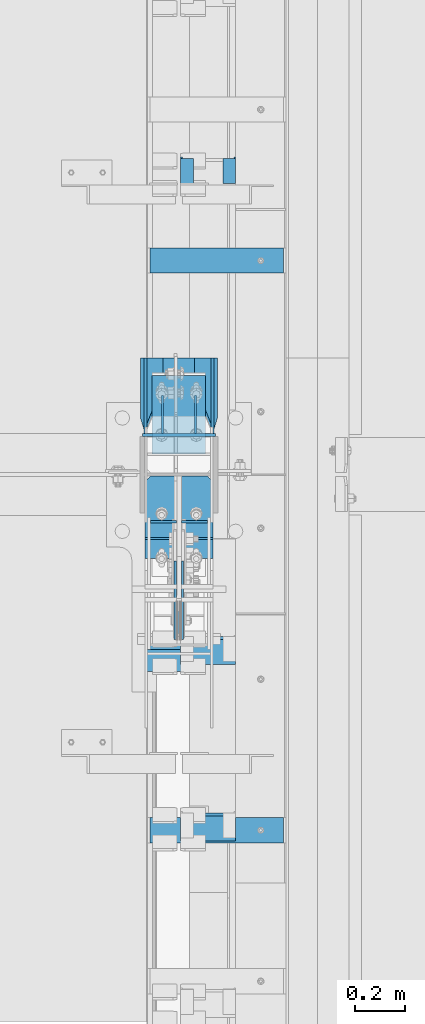
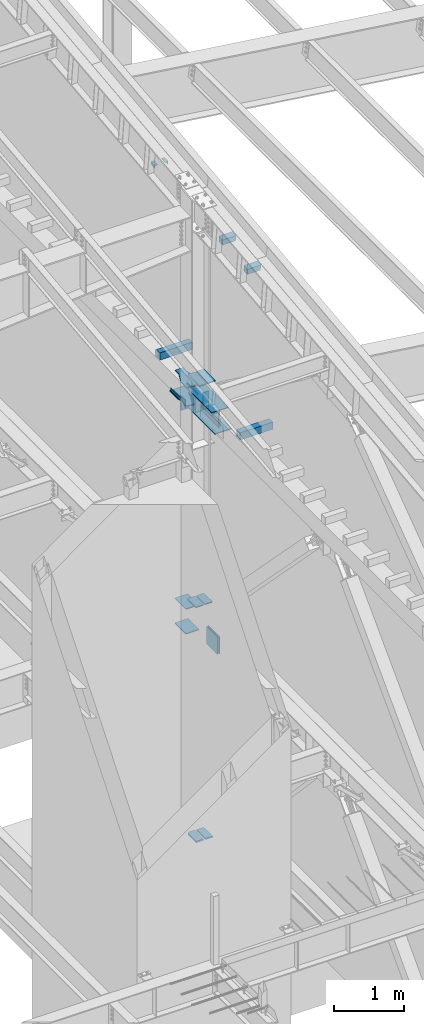
# One storey, part 838 of 1179: 28 beams, 14 elements without a shape of their own.
"""IFC2X3 building model written with IfcOpenShell, lengths in millimetres."""

from ifc_helpers import new_model, si_unit, frame, origin_with_axes, place, context, subcontext, project, spatial, faceted_brep, material, type_object, element, aggregate, save


model = new_model("IFC2X3")

# Units and contexts
model_context = context("Model", 3, precision=1e-05, world=origin_with_axes())
body_context = subcontext(model_context, "Body", "Model", "MODEL_VIEW")
ifc_project = project(units=[si_unit("LENGTHUNIT", "METRE", prefix="MILLI"), si_unit("AREAUNIT", "SQUARE_METRE"), si_unit("VOLUMEUNIT", "CUBIC_METRE"), si_unit("MASSUNIT", "GRAM", prefix="KILO"), si_unit("TIMEUNIT", "SECOND"), si_unit("PLANEANGLEUNIT", "RADIAN"), si_unit("SOLIDANGLEUNIT", "STERADIAN"), si_unit("THERMODYNAMICTEMPERATUREUNIT", "DEGREE_CELSIUS"), si_unit("LUMINOUSINTENSITYUNIT", "LUMEN")], contexts=[model_context])

# Site, building, storey
site_placement = place(None, origin_with_axes())
site = spatial("IfcSite", under=ifc_project, at=site_placement, CompositionType="ELEMENT")
building_placement = place(site_placement, origin_with_axes())
building = spatial("IfcBuilding", under=site, at=building_placement, Name="Undefined", CompositionType="ELEMENT")
storey_placement = place(building_placement, origin_with_axes())
storey = spatial("IfcBuildingStorey", under=building, at=storey_placement, Name="Undefined", CompositionType="ELEMENT", Elevation=0.0)

# Assembly, beam
assembly_1_placement = place(storey_placement, origin_with_axes())
assembly_1 = element("IfcElementAssembly", 1, at=assembly_1_placement, inside=storey, Name="COLUMN", AssemblyPlace="NOTDEFINED", PredefinedType="RIGID_FRAME")
ifc_material_1 = material(Name="STEEL/A36")
beam_type_1 = type_object("IfcBeamType", PredefinedType="NOTDEFINED")
beam_1_placement = place(assembly_1_placement, frame((24160.1625, 19388.1375, 7620.00000000912), z_axis=(0.0, 0.0, 1.0), x_axis=(1.0, 0.0, 0.0)))
beam_1 = element("IfcBeam", 2, at=beam_1_placement, type_object=beam_type_1, material=ifc_material_1, Name="PLATE", context=body_context, shape_type="Brep", body=[
    faceted_brep([(-7.27595761418343e-12, 6.35000000000036, -76.1999999999971), (0.0, 6.35000000000036, 76.2000000000044), (295.274999999994, 6.34999999999854, 76.2000000000007), (295.274999999994, 6.34999999999854, -76.2000000000007), (0.0, -6.35000000000036, 76.2000000000044), (295.274999999994, -6.34999999999854, 76.2000000000007), (7.27595761418343e-12, -6.35000000000036, -76.1999999999971), (295.274999999994, -6.34999999999854, -76.2000000000007)], [[[0, 1, 2, 3]], [[1, 4, 5, 2]], [[4, 6, 7, 5]], [[6, 0, 3, 7]], [[5, 7, 3, 2]], [[6, 4, 1, 0]]]),
])

assembly_2_placement = place(storey_placement, origin_with_axes())
assembly_2 = element("IfcElementAssembly", 3, at=assembly_2_placement, inside=storey, Name="PLATE", AssemblyPlace="NOTDEFINED", PredefinedType="RIGID_FRAME")
ifc_material_2 = material(Name="STEEL/A572-GR.50")
beam_type_2 = type_object("IfcBeamType", PredefinedType="NOTDEFINED")
beam_2_placement = place(assembly_2_placement, frame((24381.619, 18974.0139016605, 4353.48812891869), z_axis=(1.0, 0.0, 0.0), x_axis=(0.0, 1.0, 0.0)))
beam_2 = element("IfcBeam", 4, at=beam_2_placement, type_object=beam_type_2, material=ifc_material_2, Name="PLATE", context=body_context, shape_type="Brep", body=[
    faceted_brep([(225.211098339509, -9.52499999999964, 62.7065000000002), (247.436098339509, -9.52499999999964, 40.4815000000017), (247.436098339509, 9.52499999999964, 40.4815000000017), (225.211098339509, 9.52499999999964, 62.7065000000002), (247.436098339509, 9.52499999999964, -62.7065000000002), (6.18456397205591e-11, 9.52499999999964, -62.7065000000084), (0.0, 9.52499999999964, 62.7065000000002), (0.0, -9.52499999999964, 62.7065000000002), (6.18456397205591e-11, -9.52499999999964, -62.7065000000084), (247.436098339509, -9.52499999999964, -62.7065000000002)], [[[0, 1, 2, 3]], [[4, 5, 6, 3, 2]], [[6, 7, 0, 3]], [[7, 8, 9, 1, 0]], [[8, 5, 4, 9]], [[9, 4, 2, 1]], [[8, 7, 6, 5]]]),
])
aggregate(assembly_2, [beam_2])

assembly_3_placement = place(storey_placement, origin_with_axes())
assembly_3 = element("IfcElementAssembly", 5, at=assembly_3_placement, inside=storey, Name="PLATE", AssemblyPlace="NOTDEFINED", PredefinedType="RIGID_FRAME")
beam_3_placement = place(assembly_3_placement, frame((24233.981, 18974.0139016605, 4353.48812891869), z_axis=(-1.0, 0.0, 0.0), x_axis=(0.0, 1.0, 0.0)))
beam_3 = element("IfcBeam", 6, at=beam_3_placement, type_object=beam_type_2, material=ifc_material_2, Name="PLATE", context=body_context, shape_type="Brep", body=[
    faceted_brep([(225.211098339509, -9.52499999999964, 62.7065000000002), (247.436098339509, -9.52499999999964, 40.4815000000017), (247.436098339509, 9.52499999999964, 40.4815000000017), (225.211098339509, 9.52499999999964, 62.7065000000002), (247.436098339509, 9.52499999999964, -62.7065000000002), (6.18456397205591e-11, 9.52499999999964, -62.7065000000084), (0.0, 9.52499999999964, 62.7065000000002), (0.0, -9.52499999999964, 62.7065000000002), (6.18456397205591e-11, -9.52499999999964, -62.7065000000084), (247.436098339509, -9.52499999999964, -62.7065000000002)], [[[0, 1, 2, 3]], [[4, 5, 6, 3, 2]], [[6, 7, 0, 3]], [[7, 8, 9, 1, 0]], [[8, 5, 4, 9]], [[9, 4, 2, 1]], [[8, 7, 6, 5]]]),
])
aggregate(assembly_3, [beam_3])

# Beam
beam_type_3 = type_object("IfcBeamType", PredefinedType="NOTDEFINED")
beam_4_placement = place(assembly_1_placement, frame((24307.8, 19310.35, 3676.65), z_axis=(1.0, 0.0, 0.0), x_axis=(0.0, 1.0, 0.0)))
beam_4 = element("IfcBeam", 7, at=beam_4_placement, type_object=beam_type_3, material=ifc_material_2, Name="PLATE", context=body_context, shape_type="Brep", body=[
    faceted_brep([(0.0, 6.35000000000036, -107.949999999997), (0.0, 6.35000000000036, 107.949999999997), (317.5, 6.35000000000036, 107.949999999997), (317.5, 6.35000000000036, -107.949999999997), (0.0, -6.35000000000036, 107.949999999997), (317.5, -6.35000000000036, 107.949999999997), (0.0, -6.35000000000036, -107.949999999997), (317.5, -6.35000000000036, -107.949999999997)], [[[0, 1, 2, 3]], [[1, 4, 5, 2]], [[4, 6, 7, 5]], [[6, 0, 3, 7]], [[5, 7, 3, 2]], [[6, 4, 1, 0]]]),
])

beam_5_placement = place(assembly_1_placement, frame((24307.8, 19310.35, 4108.45), z_axis=(1.0, 0.0, 0.0), x_axis=(0.0, 1.0, 0.0)))
beam_5 = element("IfcBeam", 8, at=beam_5_placement, type_object=beam_type_3, material=ifc_material_2, Name="PLATE", context=body_context, shape_type="Brep", body=[
    faceted_brep([(0.0, 6.35000000000036, -107.949999999997), (0.0, 6.35000000000036, 107.949999999997), (317.5, 6.35000000000036, 107.949999999997), (317.5, 6.35000000000036, -107.949999999997), (0.0, -6.35000000000036, 107.949999999997), (317.5, -6.35000000000036, 107.949999999997), (0.0, -6.35000000000036, -107.949999999997), (317.5, -6.35000000000036, -107.949999999997)], [[[0, 1, 2, 3]], [[1, 4, 5, 2]], [[4, 6, 7, 5]], [[6, 0, 3, 7]], [[5, 7, 3, 2]], [[6, 4, 1, 0]]]),
])

# Assembly, beam
assembly_4_placement = place(storey_placement, origin_with_axes())
assembly_4 = element("IfcElementAssembly", 9, at=assembly_4_placement, inside=storey, Name="BEAM", AssemblyPlace="NOTDEFINED", PredefinedType="RIGID_FRAME")
beam_type_4 = type_object("IfcBeamType", Name="L2X2X1/4", PredefinedType="NOTDEFINED")
beam_6_placement = place(assembly_4_placement, frame((24511.0, 20405.3138166334, 11117.474837043), z_axis=(0.0, 0.112284087038014, -0.993676146336441), x_axis=(0.0, 0.993676146336441, 0.112284087038017)))
beam_6 = element("IfcBeam", 10, at=beam_6_placement, type_object=beam_type_4, material=ifc_material_1, Name="ANGLE", ObjectType="L2X2X1/4", context=body_context, shape_type="Brep", body=[
    faceted_brep([(0.0, 25.3999999999996, -25.4000000000015), (0.0, 25.3999999999996, 25.4000000000015), (101.599999999555, 25.4, 25.3999999999451), (101.599999999537, 25.4, -25.4000000000251), (7.27595761418343e-12, 19.05, 25.3999999999851), (101.599999999555, 19.05, 25.3999999999451), (0.0, 19.0499992350015, -19.0499992349996), (101.600003324515, 19.0499992350051, -19.0499992350015), (-1.09139364212751e-11, -25.4, -19.0499999999865), (101.59999999954, -25.4, -19.0500000000302), (0.0, -25.3999999999996, -25.4000000000015), (101.599999999537, -25.4, -25.4000000000251)], [[[0, 1, 2, 3]], [[1, 4, 5, 2]], [[4, 6, 7, 5]], [[6, 8, 9, 7]], [[8, 10, 11, 9]], [[10, 0, 3, 11]], [[5, 7, 9, 11, 3, 2]], [[10, 8, 6, 4, 1, 0]]]),
])
aggregate(assembly_4, [beam_6])

assembly_5_placement = place(storey_placement, origin_with_axes())
assembly_5 = element("IfcElementAssembly", 11, at=assembly_5_placement, inside=storey, Name="BEAM", AssemblyPlace="NOTDEFINED", PredefinedType="RIGID_FRAME")
beam_7_placement = place(assembly_5_placement, frame((24340.34375, 20405.3138166334, 11117.474837043), z_axis=(1.0, 0.0, 0.0), x_axis=(0.0, 0.993676146336441, 0.112284087038017)))
beam_7 = element("IfcBeam", 12, at=beam_7_placement, type_object=beam_type_4, material=ifc_material_1, Name="ANGLE", ObjectType="L2X2X1/4", context=body_context, shape_type="Brep", body=[
    faceted_brep([(0.0, 25.3999999999996, -25.4000000000015), (0.0, 25.3999999999996, 25.4000000000015), (101.599999999555, 25.4, 25.3999999999451), (101.599999999537, 25.4, -25.4000000000251), (7.27595761418343e-12, 19.05, 25.3999999999851), (101.599999999555, 19.05, 25.3999999999451), (0.0, 19.0499992350015, -19.0499992349996), (101.600003324515, 19.0499992350051, -19.0499992350015), (-1.09139364212751e-11, -25.4, -19.0499999999865), (101.59999999954, -25.4, -19.0500000000302), (0.0, -25.3999999999996, -25.4000000000015), (101.599999999537, -25.4, -25.4000000000251)], [[[0, 1, 2, 3]], [[1, 4, 5, 2]], [[4, 6, 7, 5]], [[6, 8, 9, 7]], [[8, 10, 11, 9]], [[10, 0, 3, 11]], [[5, 7, 9, 11, 3, 2]], [[10, 8, 6, 4, 1, 0]]]),
])
aggregate(assembly_5, [beam_7])

# Beam
beam_type_5 = type_object("IfcBeamType", PredefinedType="NOTDEFINED")
beam_8_placement = place(assembly_1_placement, frame((24234.775, 18888.9023695225, 8262.24369604468), z_axis=(-1.0, 0.0, 0.0), x_axis=(0.0, 1.0, 0.0)))
beam_8 = element("IfcBeam", 13, at=beam_8_placement, type_object=beam_type_5, material=ifc_material_2, Name="PLATE", context=body_context, shape_type="Brep", body=[
    faceted_brep([(332.547630477533, 9.52499999999964, 41.2750000000015), (310.322630477534, 9.52499999999964, 63.5), (310.322630477534, -9.52499999999964, 63.5), (332.547630477533, -9.52499999999964, 41.2750000000015), (332.547630477533, 9.52499999999964, -63.5), (0.0, 9.52500000000146, -63.5), (0.0, 9.52500000000146, 63.5), (0.0, -9.52500000000146, 63.5), (0.0, -9.52500000000146, -63.5), (332.547630477533, -9.52499999999964, -63.5)], [[[0, 1, 2, 3]], [[4, 5, 6, 1, 0]], [[6, 7, 2, 1]], [[7, 8, 9, 3, 2]], [[8, 5, 4, 9]], [[9, 4, 0, 3]], [[8, 7, 6, 5]]]),
])

beam_9_placement = place(assembly_1_placement, frame((24380.825, 18888.9023695225, 8262.24369604468), z_axis=(-1.0, 0.0, 0.0), x_axis=(0.0, 1.0, 0.0)))
beam_9 = element("IfcBeam", 14, at=beam_9_placement, type_object=beam_type_5, material=ifc_material_2, Name="PLATE", context=body_context, shape_type="Brep", body=[
    faceted_brep([(310.322630477534, 9.52499999999964, -63.5), (332.547630477533, 9.52499999999964, -41.2750000000015), (332.547630477533, -9.52499999999964, -41.2750000000015), (310.322630477534, -9.52499999999964, -63.5), (0.0, 9.52500000000146, -63.5), (0.0, 9.52500000000146, 63.5), (332.547630477533, 9.52499999999964, 63.5), (0.0, -9.52500000000146, 63.5), (332.547630477533, -9.52499999999964, 63.5), (0.0, -9.52500000000146, -63.5)], [[[0, 1, 2, 3]], [[4, 5, 6, 1, 0]], [[5, 7, 8, 6]], [[8, 7, 9, 3, 2]], [[9, 4, 0, 3]], [[6, 8, 2, 1]], [[9, 7, 5, 4]]]),
])

beam_type_6 = type_object("IfcBeamType", PredefinedType="NOTDEFINED")
beam_10_placement = place(assembly_1_placement, frame((24307.8, 19221.45, 7861.3), z_axis=(0.0, 0.0, 1.0), x_axis=(0.0, -1.0, 0.0)))
beam_10 = element("IfcBeam", 15, at=beam_10_placement, type_object=beam_type_6, material=ifc_material_2, Name="PLATE", context=body_context, shape_type="Brep", body=[
    faceted_brep([(0.0, 9.52500000000146, -152.4), (0.0, 9.52500000000146, 152.4), (676.100196486103, 9.52500000000146, 152.4), (676.100196486103, 9.52500000000146, -152.4), (0.0, -9.52500000000146, 152.4), (676.100196486103, -9.52500000000146, 152.4), (0.0, -9.52500000000146, -152.4), (676.100196486103, -9.52500000000146, -152.4)], [[[0, 1, 2, 3]], [[1, 4, 5, 2]], [[4, 6, 7, 5]], [[6, 0, 3, 7]], [[5, 7, 3, 2]], [[6, 4, 1, 0]]]),
])

beam_type_7 = type_object("IfcBeamType", PredefinedType="NOTDEFINED")
beam_11_placement = place(assembly_1_placement, frame((24317.325, 19037.3, 7861.3), z_axis=(0.0, 0.0, 1.0), x_axis=(1.0, 0.0, 0.0)))
beam_11 = element("IfcBeam", 16, at=beam_11_placement, type_object=beam_type_7, material=ifc_material_2, Name="PLATE", context=body_context, shape_type="Brep", body=[
    faceted_brep([(0.0, 4.76250000000073, -152.4), (0.0, 4.76250000000073, 152.4), (104.775000000001, 4.76250000000073, 152.4), (104.775000000001, 4.76250000000073, -152.4), (0.0, -4.76250000000073, 152.4), (104.775000000001, -4.76250000000073, 152.4), (0.0, -4.76250000000073, -152.4), (104.775000000001, -4.76250000000073, -152.4)], [[[0, 1, 2, 3]], [[1, 4, 5, 2]], [[4, 6, 7, 5]], [[6, 0, 3, 7]], [[5, 7, 3, 2]], [[6, 4, 1, 0]]]),
])

beam_12_placement = place(assembly_1_placement, frame((24193.5, 19037.3, 7861.3), z_axis=(0.0, 0.0, 1.0), x_axis=(1.0, 0.0, 0.0)))
beam_12 = element("IfcBeam", 17, at=beam_12_placement, type_object=beam_type_7, material=ifc_material_2, Name="PLATE", context=body_context, shape_type="Brep", body=[
    faceted_brep([(0.0, 4.76250000000073, -152.4), (0.0, 4.76250000000073, 152.4), (104.775000000001, 4.76250000000073, 152.4), (104.775000000001, 4.76250000000073, -152.4), (0.0, -4.76250000000073, 152.4), (104.775000000001, -4.76250000000073, 152.4), (0.0, -4.76250000000073, -152.4), (104.775000000001, -4.76250000000073, -152.4)], [[[0, 1, 2, 3]], [[1, 4, 5, 2]], [[4, 6, 7, 5]], [[6, 0, 3, 7]], [[5, 7, 3, 2]], [[6, 4, 1, 0]]]),
])

beam_type_8 = type_object("IfcBeamType", PredefinedType="NOTDEFINED")
beam_13_placement = place(assembly_1_placement, frame((24307.8, 18434.2248035139, 7702.55), z_axis=(-1.0, 0.0, 0.0), x_axis=(0.0, 1.0, 0.0)))
beam_13 = element("IfcBeam", 18, at=beam_13_placement, type_object=beam_type_8, material=ifc_material_2, Name="PLATE", context=body_context, shape_type="Brep", body=[
    faceted_brep([(765.000197461464, 6.35000000000036, -136.525000000001), (787.225197461465, 6.35000000000036, -114.299999999999), (787.225197461465, -6.35000000000036, -114.299999999999), (765.000197461464, -6.35000000000036, -136.525000000001), (787.225197461465, 6.35000000000036, 114.299999999999), (765.000197461464, 6.35000000000036, 136.525000000001), (765.000197461464, -6.35000000000036, 136.525000000001), (787.225197461465, -6.35000000000036, 114.299999999999), (0.0, 6.35000000000036, -136.525000000001), (0.0, 6.35000000000036, 136.525000000001), (0.0, -6.35000000000036, 136.525000000001), (0.0, -6.35000000000036, -136.525000000001)], [[[0, 1, 2, 3]], [[4, 5, 6, 7]], [[8, 9, 5, 4, 1, 0]], [[9, 10, 6, 5]], [[7, 6, 10, 11, 3, 2]], [[11, 8, 0, 3]], [[4, 7, 2, 1]], [[11, 10, 9, 8]]]),
])

beam_14_placement = place(assembly_1_placement, frame((24307.8, 18523.1248035139, 8020.05), z_axis=(-1.0, 0.0, 0.0), x_axis=(0.0, 1.0, 0.0)))
beam_14 = element("IfcBeam", 19, at=beam_14_placement, type_object=beam_type_8, material=ifc_material_2, Name="PLATE", context=body_context, shape_type="Brep", body=[
    faceted_brep([(676.100197461472, 6.35000000000036, -136.525000000001), (698.325197461472, 6.35000000000036, -114.299999999999), (698.325197461472, -6.35000000000036, -114.299999999999), (676.100197461472, -6.35000000000036, -136.525000000001), (698.325197461472, 6.35000000000036, 114.299999999999), (676.100197461472, 6.35000000000036, 136.525000000001), (676.100197461472, -6.35000000000036, 136.525000000001), (698.325197461472, -6.35000000000036, 114.299999999999), (0.0, 6.35000000000036, -136.525000000001), (0.0, 6.35000000000036, 136.525000000001), (0.0, -6.35000000000036, 136.525000000001), (0.0, -6.35000000000036, -136.525000000001)], [[[0, 1, 2, 3]], [[4, 5, 6, 7]], [[8, 9, 5, 4, 1, 0]], [[9, 10, 6, 5]], [[7, 6, 10, 11, 3, 2]], [[11, 8, 0, 3]], [[4, 7, 2, 1]], [[11, 10, 9, 8]]]),
])

# Assembly, beam
assembly_6_placement = place(storey_placement, origin_with_axes())
assembly_6 = element("IfcElementAssembly", 20, at=assembly_6_placement, inside=storey, Name="PLATE", AssemblyPlace="NOTDEFINED", PredefinedType="RIGID_FRAME")
beam_type_9 = type_object("IfcBeamType", PredefinedType="NOTDEFINED")
beam_15_placement = place(assembly_6_placement, frame((24232.3935, 18966.3380811392, 267.318748335633), z_axis=(-1.0, 0.0, 0.0), x_axis=(0.0, 1.0, 0.0)))
beam_15 = element("IfcBeam", 21, at=beam_15_placement, type_object=beam_type_9, material=ifc_material_2, Name="PLATE", context=body_context, shape_type="Brep", body=[
    faceted_brep([(255.111918860846, 12.7, 38.8940000000002), (232.886918860846, 12.7, 61.1189999999988), (232.886918860846, -12.7, 61.1189999999988), (255.111918860846, -12.7, 38.8940000000002), (255.111918860846, 12.7, -61.1189999999988), (0.0, 12.7, -61.1189999999988), (0.0, 12.7, 61.1189999999988), (0.0, -12.7, 61.1189999999988), (0.0, -12.7, -61.1189999999988), (255.111918860846, -12.7, -61.1189999999988)], [[[0, 1, 2, 3]], [[4, 5, 6, 1, 0]], [[6, 7, 2, 1]], [[7, 8, 9, 3, 2]], [[8, 5, 4, 9]], [[9, 4, 0, 3]], [[8, 7, 6, 5]]]),
])
aggregate(assembly_6, [beam_15])

assembly_7_placement = place(storey_placement, origin_with_axes())
assembly_7 = element("IfcElementAssembly", 22, at=assembly_7_placement, inside=storey, Name="PLATE", AssemblyPlace="NOTDEFINED", PredefinedType="RIGID_FRAME")
beam_16_placement = place(assembly_7_placement, frame((24383.2065, 18966.3380811392, 267.318748335633), z_axis=(1.0, 0.0, 0.0), x_axis=(0.0, 1.0, 0.0)))
beam_16 = element("IfcBeam", 23, at=beam_16_placement, type_object=beam_type_9, material=ifc_material_2, Name="PLATE", context=body_context, shape_type="Brep", body=[
    faceted_brep([(255.111918860846, 12.7, 38.8940000000002), (232.886918860846, 12.7, 61.1189999999988), (232.886918860846, -12.7, 61.1189999999988), (255.111918860846, -12.7, 38.8940000000002), (255.111918860846, 12.7, -61.1189999999988), (0.0, 12.7, -61.1189999999988), (0.0, 12.7, 61.1189999999988), (0.0, -12.7, 61.1189999999988), (0.0, -12.7, -61.1189999999988), (255.111918860846, -12.7, -61.1189999999988)], [[[0, 1, 2, 3]], [[4, 5, 6, 1, 0]], [[6, 7, 2, 1]], [[7, 8, 9, 3, 2]], [[8, 5, 4, 9]], [[9, 4, 0, 3]], [[8, 7, 6, 5]]]),
])
aggregate(assembly_7, [beam_16])

assembly_8_placement = place(storey_placement, origin_with_axes())
assembly_8 = element("IfcElementAssembly", 24, at=assembly_8_placement, inside=storey, Name="PLATE", AssemblyPlace="NOTDEFINED", PredefinedType="RIGID_FRAME")
beam_type_10 = type_object("IfcBeamType", PredefinedType="NOTDEFINED")
beam_17_placement = place(assembly_8_placement, frame((24293.5125, 18562.3015666254, 3892.55), z_axis=(0.0, 0.0, -1.0), x_axis=(0.0, 1.0, 0.0)))
beam_17 = element("IfcBeam", 25, at=beam_17_placement, type_object=beam_type_10, material=ifc_material_2, Name="PLATE", context=body_context, shape_type="Brep", body=[
    faceted_brep([(0.0, 4.76250000000073, -152.4), (0.0, 4.76250000000073, 152.4), (317.5, 4.76250000000073, 152.4), (317.5, 4.76250000000073, -152.4), (0.0, -4.76250000000073, 152.4), (317.5, -4.76250000000073, 152.4), (0.0, -4.76250000000073, -152.4), (317.5, -4.76250000000073, -152.4)], [[[0, 1, 2, 3]], [[1, 4, 5, 2]], [[4, 6, 7, 5]], [[6, 0, 3, 7]], [[5, 7, 3, 2]], [[6, 4, 1, 0]]]),
])
aggregate(assembly_8, [beam_17])

assembly_9_placement = place(storey_placement, origin_with_axes())
assembly_9 = element("IfcElementAssembly", 26, at=assembly_9_placement, inside=storey, Name="PLATE", AssemblyPlace="NOTDEFINED", PredefinedType="RIGID_FRAME")
beam_18_placement = place(assembly_9_placement, frame((24322.0875, 18879.8015666254, 3892.55), z_axis=(0.0, 0.0, -1.0), x_axis=(0.0, -1.0, 0.0)))
beam_18 = element("IfcBeam", 27, at=beam_18_placement, type_object=beam_type_10, material=ifc_material_2, Name="PLATE", context=body_context, shape_type="Brep", body=[
    faceted_brep([(0.0, 4.76250000000073, -152.4), (0.0, 4.76250000000073, 152.4), (317.5, 4.76250000000073, 152.4), (317.5, 4.76250000000073, -152.4), (0.0, -4.76250000000073, 152.4), (317.5, -4.76250000000073, 152.4), (0.0, -4.76250000000073, -152.4), (317.5, -4.76250000000073, -152.4)], [[[0, 1, 2, 3]], [[1, 4, 5, 2]], [[4, 6, 7, 5]], [[6, 0, 3, 7]], [[5, 7, 3, 2]], [[6, 4, 1, 0]]]),
])
aggregate(assembly_9, [beam_18])

# Beam
beam_type_11 = type_object("IfcBeamType", PredefinedType="NOTDEFINED")
beam_19_placement = place(assembly_1_placement, frame((24172.8625, 19699.2875, 7727.95000000912), z_axis=(0.0, 0.0, 1.0), x_axis=(0.0, -1.0, 0.0)))
beam_19 = element("IfcBeam", 28, at=beam_19_placement, type_object=beam_type_11, material=ifc_material_1, Name="PLATE", context=body_context, shape_type="Brep", body=[
    faceted_brep([(0.0, 6.34999999999854, -19.0499999999993), (0.0, 6.35000000000036, 19.0499999999993), (317.5, 6.34999999999854, 19.0499999999993), (317.5, 6.34999999999854, -19.0499999999993), (0.0, -6.35000000000036, 19.0499999999993), (317.5, -6.34999999999854, 19.0499999999993), (0.0, -6.34999999999854, -19.0499999999993), (317.5, -6.34999999999854, -19.0499999999993)], [[[0, 1, 2, 3]], [[1, 4, 5, 2]], [[4, 6, 7, 5]], [[6, 0, 3, 7]], [[5, 7, 3, 2]], [[6, 4, 1, 0]]]),
])

beam_20_placement = place(assembly_1_placement, frame((24442.7375, 19699.2875, 7727.95000000912), z_axis=(0.0, 0.0, 1.0), x_axis=(0.0, -1.0, 0.0)))
beam_20 = element("IfcBeam", 29, at=beam_20_placement, type_object=beam_type_11, material=ifc_material_1, Name="PLATE", context=body_context, shape_type="Brep", body=[
    faceted_brep([(0.0, 6.34999999999854, -19.0499999999993), (0.0, 6.35000000000036, 19.0499999999993), (317.5, 6.34999999999854, 19.0499999999993), (317.5, 6.34999999999854, -19.0499999999993), (0.0, -6.35000000000036, 19.0499999999993), (317.5, -6.34999999999854, 19.0499999999993), (0.0, -6.34999999999854, -19.0499999999993), (317.5, -6.34999999999854, -19.0499999999993)], [[[0, 1, 2, 3]], [[1, 4, 5, 2]], [[4, 6, 7, 5]], [[6, 0, 3, 7]], [[5, 7, 3, 2]], [[6, 4, 1, 0]]]),
])

beam_type_12 = type_object("IfcBeamType", PredefinedType="NOTDEFINED")
beam_21_placement = place(assembly_1_placement, frame((24241.125, 19546.8875, 7620.00000000912), z_axis=(0.0, 0.0, 1.0), x_axis=(0.0, -1.0, 0.0)))
beam_21 = element("IfcBeam", 30, at=beam_21_placement, type_object=beam_type_12, material=ifc_material_1, Name="PLATE", context=body_context, shape_type="Brep", body=[
    faceted_brep([(152.4, -4.76249999999709, 76.2), (152.4, -4.76249999999709, -76.2), (152.4, 4.76249999999709, -76.2), (152.4, 4.76249999999709, 76.2), (0.0, 4.76249999999982, 76.1999999999971), (0.0, -4.76249999999982, 76.1999999999971)], [[[0, 1, 2, 3]], [[3, 2, 4]], [[4, 5, 0, 3]], [[0, 5, 1]], [[4, 2, 1, 5]]]),
])

beam_22_placement = place(assembly_1_placement, frame((24374.475, 19546.8875, 7620.00000000912), z_axis=(0.0, 0.0, 1.0), x_axis=(0.0, -1.0, 0.0)))
beam_22 = element("IfcBeam", 31, at=beam_22_placement, type_object=beam_type_12, material=ifc_material_1, Name="PLATE", context=body_context, shape_type="Brep", body=[
    faceted_brep([(152.4, -4.76249999999709, 76.2), (152.4, -4.76249999999709, -76.2), (152.4, 4.76249999999709, -76.2), (152.4, 4.76249999999709, 76.2), (0.0, 4.76249999999982, 76.1999999999971), (0.0, -4.76249999999982, 76.1999999999971)], [[[0, 1, 2, 3]], [[3, 2, 4]], [[4, 5, 0, 3]], [[0, 5, 1]], [[4, 2, 1, 5]]]),
])

# Assembly, beam
assembly_10_placement = place(storey_placement, origin_with_axes())
assembly_10 = element("IfcElementAssembly", 32, at=assembly_10_placement, inside=storey, Name="PLATE", AssemblyPlace="NOTDEFINED", PredefinedType="RIGID_FRAME")
beam_type_13 = type_object("IfcBeamType", PredefinedType="NOTDEFINED")
beam_23_placement = place(assembly_10_placement, frame((24307.8, 19699.2875, 8023.22500000912), z_axis=(1.0, 0.0, 0.0), x_axis=(0.0, -1.0, 0.0)))
beam_23 = element("IfcBeam", 33, at=beam_23_placement, type_object=beam_type_13, material=ifc_material_1, Name="PLATE", context=body_context, shape_type="Brep", body=[
    faceted_brep([(465.137499999997, -7.9375, -114.300000762945), (442.912499999999, -7.9375, -136.525000762944), (442.912500000006, 7.9375, -136.525000762944), (465.137500000004, 7.9375, -114.300000762945), (465.137500000004, 7.9375, 114.300000762938), (442.912500000006, 7.9375, 136.525000762937), (442.912499999999, -7.9375, 136.525000762937), (465.137499999997, -7.9375, 114.300000762938), (96.7084051981856, -7.9375, 63.4999984741225), (96.7084051981856, 7.9375, 63.4999984741225), (0.0, 7.9375, 63.5), (0.0, -7.9375, 63.5), (99.1209783650102, -7.9375, 63.6148350254298), (99.1209783650102, 7.9375, 63.6148350254298), (101.511736446291, -7.9375, 63.958306298744), (101.511736446291, 7.9375, 63.958306298744), (103.859061613901, -7.9375, 64.5273065415386), (103.859061613901, 7.9375, 64.5273065415386), (106.141728770905, -7.9375, 65.3166907123523), (106.141728770905, 7.9375, 65.3166907123523), (284.162490278406, -7.9375, 136.524999999998), (284.162490278406, 7.9375, 136.525000000001), (0.0, -7.9375, -63.5), (0.0, 7.9375, -63.5), (96.7084055018695, 7.9375, -63.5), (96.7084055018695, -7.9375, -63.5), (99.1209785229439, 7.9375, -63.6148365373992), (99.1209785229439, -7.9375, -63.6148365373992), (101.511736462435, 7.9375, -63.9583077692478), (101.511736462435, -7.9375, -63.9583077692478), (103.859061496114, 7.9375, -64.5273079437611), (103.859061496114, -7.9375, -64.5273079437611), (106.141728530831, 7.9375, -65.3166920207259), (106.141728530831, -7.9375, -65.3166920207259), (284.162502485447, -7.9375, -136.525001525879), (284.162502485447, 7.9375, -136.525000000001)], [[[0, 1, 2, 3]], [[4, 5, 6, 7]], [[8, 9, 10, 11]], [[12, 13, 9, 8]], [[14, 15, 13, 12]], [[16, 17, 15, 14]], [[18, 19, 17, 16]], [[20, 21, 19, 18]], [[22, 23, 24, 25]], [[25, 24, 26, 27]], [[27, 26, 28, 29]], [[29, 28, 30, 31]], [[31, 30, 32, 33]], [[34, 33, 32, 35]], [[34, 35, 2, 1]], [[4, 7, 0, 3]], [[7, 6, 20, 18, 16, 14, 12, 8, 11, 22, 25, 27, 29, 31, 33, 34, 1, 0]], [[22, 11, 10, 23]], [[35, 32, 30, 28, 26, 24, 23, 10, 9, 13, 15, 17, 19, 21, 5, 4, 3, 2]], [[21, 20, 6, 5]]]),
])
aggregate(assembly_10, [beam_23])

assembly_11_placement = place(storey_placement, origin_with_axes())
assembly_11 = element("IfcElementAssembly", 34, at=assembly_11_placement, inside=storey, Name="BEAM", AssemblyPlace="NOTDEFINED", PredefinedType="RIGID_FRAME")
ifc_material_3 = material()
beam_type_14 = type_object("IfcBeamType", Name="HSS4X4X5/16", PredefinedType="NOTDEFINED")
beam_24_placement = place(assembly_11_placement, frame((24307.8, 17805.9346927869, 10900.081017617), z_axis=(0.0, -0.112284087038017, 0.993676146336441), x_axis=(1.0, 0.0, 0.0)))
beam_24 = element("IfcBeam", 35, at=beam_24_placement, type_object=beam_type_14, material=ifc_material_3, Name="BEAM", ObjectType="HSS4X4X5/16", context=body_context, shape_type="Brep", body=[
    faceted_brep([(7.14374999999757, 42.8624999999884, -42.8624999999574), (7.14374999999757, -42.8624999999593, -42.862499999992), (228.600000000002, -42.8624999999593, -42.862499999992), (228.600000000002, 42.8624999999884, -42.8624999999574), (7.14374999999757, -42.8624999999956, 42.8624999999611), (228.600000000002, -42.8624999999956, 42.8624999999611), (7.14374999999757, 42.862499999952, 42.8624999999938), (228.600000000002, 42.862499999952, 42.8624999999938), (7.14374999999757, 50.7999999999884, -50.7999999999502), (7.14374999999757, 50.7999999999447, 50.7999999999938), (228.600000000002, 50.7999999999447, 50.7999999999938), (228.600000000002, 50.7999999999884, -50.7999999999502), (7.14374999999757, -50.7999999999956, 50.799999999952), (228.600000000002, -50.7999999999956, 50.799999999952), (7.14374999999757, -50.7999999999556, -50.7999999999902), (228.600000000002, -50.7999999999556, -50.7999999999902)], [[[0, 1, 2, 3]], [[1, 4, 5, 2]], [[4, 6, 7, 5]], [[6, 0, 3, 7]], [[8, 9, 10, 11]], [[9, 12, 13, 10]], [[12, 14, 15, 13]], [[14, 8, 11, 15]], [[13, 15, 11, 10], [5, 7, 3, 2]], [[14, 12, 9, 8], [6, 4, 1, 0]]]),
])
aggregate(assembly_11, [beam_24])

assembly_12_placement = place(storey_placement, origin_with_axes())
assembly_12 = element("IfcElementAssembly", 36, at=assembly_12_placement, inside=storey, Name="BEAM", AssemblyPlace="NOTDEFINED", PredefinedType="RIGID_FRAME")
beam_25_placement = place(assembly_12_placement, frame((24307.8, 18517.565655167, 10980.5496956301), z_axis=(0.0, -0.112284087038017, 0.993676146336441), x_axis=(1.0, 0.0, 0.0)))
beam_25 = element("IfcBeam", 37, at=beam_25_placement, type_object=beam_type_14, material=ifc_material_3, Name="BEAM", ObjectType="HSS4X4X5/16", context=body_context, shape_type="Brep", body=[
    faceted_brep([(7.14374999999757, 42.8624999999884, -42.8624999999574), (7.14374999999757, -42.8624999999593, -42.862499999992), (228.600000000002, -42.8624999999593, -42.862499999992), (228.600000000002, 42.8624999999884, -42.8624999999574), (7.14374999999757, -42.8624999999956, 42.8624999999611), (228.600000000002, -42.8624999999956, 42.8624999999611), (7.14374999999757, 42.862499999952, 42.8624999999938), (228.600000000002, 42.862499999952, 42.8624999999938), (7.14374999999757, 50.7999999999884, -50.7999999999502), (7.14374999999757, 50.7999999999447, 50.7999999999938), (228.600000000002, 50.7999999999447, 50.7999999999938), (228.600000000002, 50.7999999999884, -50.7999999999502), (7.14374999999757, -50.7999999999956, 50.799999999952), (228.600000000002, -50.7999999999956, 50.799999999952), (7.14374999999757, -50.7999999999556, -50.7999999999902), (228.600000000002, -50.7999999999556, -50.7999999999902)], [[[0, 1, 2, 3]], [[1, 4, 5, 2]], [[4, 6, 7, 5]], [[6, 0, 3, 7]], [[8, 9, 10, 11]], [[9, 12, 13, 10]], [[12, 14, 15, 13]], [[14, 8, 11, 15]], [[13, 15, 11, 10], [5, 7, 3, 2]], [[14, 12, 9, 8], [6, 4, 1, 0]]]),
])
aggregate(assembly_12, [beam_25])

assembly_13_placement = place(storey_placement, origin_with_axes())
assembly_13 = element("IfcElementAssembly", 38, at=assembly_13_placement, inside=storey, Name="BEAM", AssemblyPlace="NOTDEFINED", PredefinedType="RIGID_FRAME")
beam_type_15 = type_object("IfcBeamType", Name="HSS5X4X3/8", PredefinedType="NOTDEFINED")
beam_26_placement = place(assembly_13_placement, frame((24180.8, 20091.4, 8077.19999998781), z_axis=(0.0, 0.0, 1.0), x_axis=(1.0, 0.0, 0.0)))
beam_26 = element("IfcBeam", 39, at=beam_26_placement, type_object=beam_type_15, material=ifc_material_3, Name="BEAM", ObjectType="HSS5X4X3/8", context=body_context, shape_type="Brep", body=[
    faceted_brep([(9.52500000000146, 41.2750000000015, -53.9750000000004), (9.52500000000146, -41.2750000000015, -53.9750000000004), (549.274999999994, -41.2750000000015, -53.9750000000004), (549.274999999994, 41.2750000000015, -53.9750000000004), (9.52500000000146, -41.2750000000015, 53.9750000000004), (549.274999999994, -41.2750000000015, 53.9750000000004), (9.52500000000146, 41.2750000000015, 53.9750000000004), (549.274999999994, 41.2750000000015, 53.9750000000004), (9.52500000000146, 50.7999999999993, -63.5), (9.52500000000146, 50.7999999999993, 63.5), (549.274999999994, 50.7999999999993, 63.5), (549.274999999994, 50.7999999999993, -63.5), (9.52500000000146, -50.7999999999993, 63.5), (549.274999999994, -50.7999999999993, 63.5), (9.52500000000146, -50.7999999999993, -63.5), (549.274999999994, -50.7999999999993, -63.5)], [[[0, 1, 2, 3]], [[1, 4, 5, 2]], [[4, 6, 7, 5]], [[6, 0, 3, 7]], [[8, 9, 10, 11]], [[9, 12, 13, 10]], [[12, 14, 15, 13]], [[14, 8, 11, 15]], [[13, 15, 11, 10], [5, 7, 3, 2]], [[14, 12, 9, 8], [6, 4, 1, 0]]]),
])
aggregate(assembly_13, [beam_26])

assembly_14_placement = place(storey_placement, origin_with_axes())
assembly_14 = element("IfcElementAssembly", 40, at=assembly_14_placement, inside=storey, Name="BEAM", AssemblyPlace="NOTDEFINED", PredefinedType="RIGID_FRAME")
beam_27_placement = place(assembly_14_placement, frame((24180.8, 17792.7, 8077.19999998781), z_axis=(0.0, 0.0, 1.0), x_axis=(1.0, 0.0, 0.0)))
beam_27 = element("IfcBeam", 41, at=beam_27_placement, type_object=beam_type_15, material=ifc_material_3, Name="BEAM", ObjectType="HSS5X4X3/8", context=body_context, shape_type="Brep", body=[
    faceted_brep([(9.52500000000146, 41.2750000000015, -53.9750000000004), (9.52500000000146, -41.2750000000015, -53.9750000000004), (549.274999999994, -41.2750000000015, -53.9750000000004), (549.274999999994, 41.2750000000015, -53.9750000000004), (9.52500000000146, -41.2750000000015, 53.9750000000004), (549.274999999994, -41.2750000000015, 53.9750000000004), (9.52500000000146, 41.2750000000015, 53.9750000000004), (549.274999999994, 41.2750000000015, 53.9750000000004), (9.52500000000146, 50.7999999999993, -63.5), (9.52500000000146, 50.7999999999993, 63.5), (549.274999999994, 50.7999999999993, 63.5), (549.274999999994, 50.7999999999993, -63.5), (9.52500000000146, -50.7999999999993, 63.5), (549.274999999994, -50.7999999999993, 63.5), (9.52500000000146, -50.7999999999993, -63.5), (549.274999999994, -50.7999999999993, -63.5)], [[[0, 1, 2, 3]], [[1, 4, 5, 2]], [[4, 6, 7, 5]], [[6, 0, 3, 7]], [[8, 9, 10, 11]], [[9, 12, 13, 10]], [[12, 14, 15, 13]], [[14, 8, 11, 15]], [[13, 15, 11, 10], [5, 7, 3, 2]], [[14, 12, 9, 8], [6, 4, 1, 0]]]),
])
aggregate(assembly_14, [beam_27])

# Beam
beam_type_16 = type_object("IfcBeamType", PredefinedType="NOTDEFINED")
beam_28_placement = place(assembly_1_placement, frame((24307.8, 19699.2875, 7702.55000000912), z_axis=(1.0, 0.0, 0.0), x_axis=(0.0, -1.0, 0.0)))
beam_28 = element("IfcBeam", 42, at=beam_28_placement, type_object=beam_type_16, material=ifc_material_1, Name="PLATE", context=body_context, shape_type="Brep", body=[
    faceted_brep([(465.137500000001, -6.35000000000036, -114.300000762942), (442.9125, -6.35000000000036, -136.52500076294), (442.9125, 6.35000000000036, -136.52500076294), (465.137500000001, 6.35000000000036, -114.300000762942), (465.137500000001, 6.35000000000036, 114.300000762942), (442.9125, 6.35000000000036, 136.52500076294), (442.9125, -6.35000000000036, 136.52500076294), (465.137500000001, -6.35000000000036, 114.300000762942), (241.300006103516, -6.35000000000036, -155.575000000001), (241.300006103516, 6.35000000000036, -155.575000000001), (304.799990844727, 6.35000000000036, -136.52500076294), (304.799990844727, -6.35000000000036, -136.52500076294), (0.0, -6.35000000000036, -155.575000000001), (0.0, -6.35000000000036, 155.575000000001), (0.0, 6.35000000000036, 155.575000000001), (0.0, 6.35000000000036, -155.575000000001), (241.300006103516, -6.35000000000036, 155.575000000001), (241.300006103516, 6.35000000000036, 155.575000000001), (304.799990844727, -6.35000000000036, 136.52500076294), (304.799990844727, 6.35000000000036, 136.52500076294)], [[[0, 1, 2, 3]], [[4, 5, 6, 7]], [[8, 9, 10, 11]], [[11, 10, 2, 1]], [[12, 13, 14, 15]], [[14, 13, 16, 17]], [[18, 19, 17, 16]], [[19, 18, 6, 5]], [[4, 7, 0, 3]], [[10, 9, 15, 14, 17, 19, 5, 4, 3, 2]], [[12, 15, 9, 8]], [[7, 6, 18, 16, 13, 12, 8, 11, 1, 0]]]),
])

aggregate(assembly_1, [beam_10, beam_8, beam_9, beam_13, beam_14, beam_11, beam_12, beam_19, beam_21, beam_20, beam_22, beam_28, beam_1, beam_4, beam_5])

save(model, "model.ifc")
